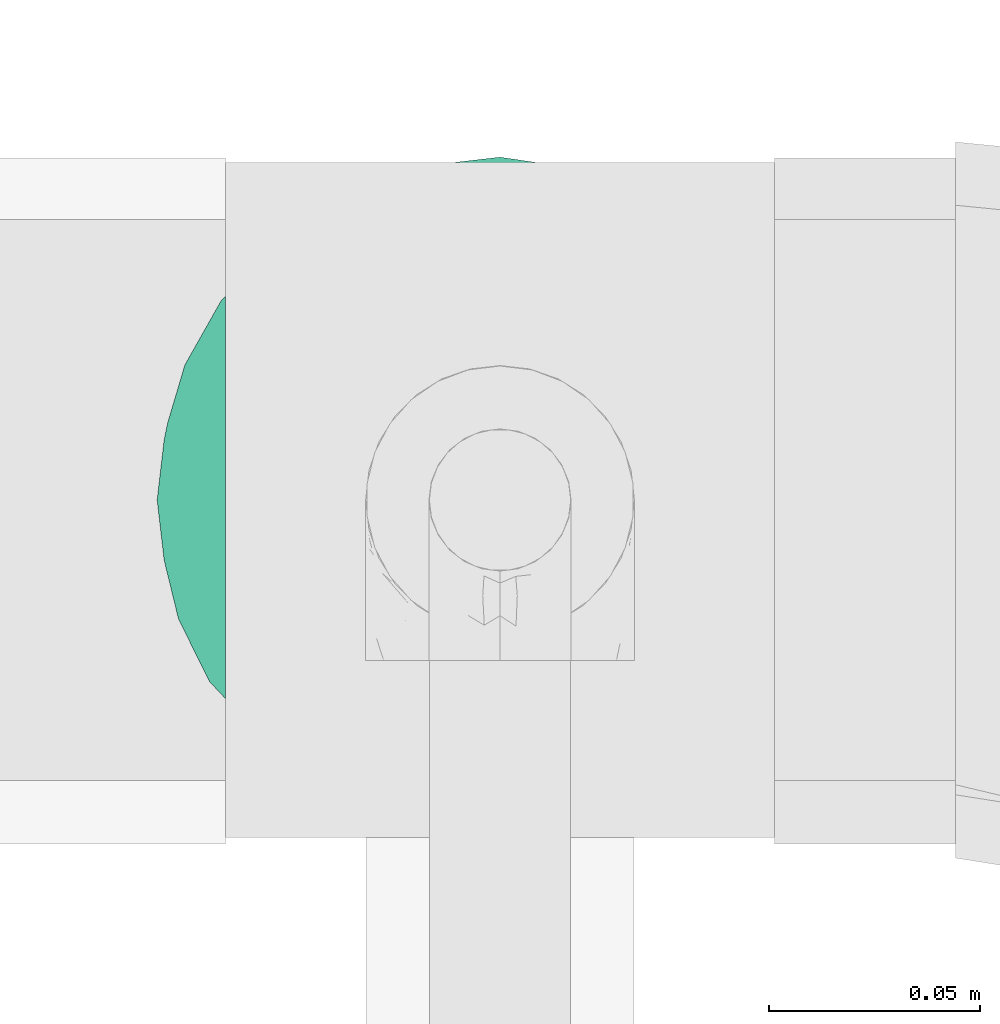
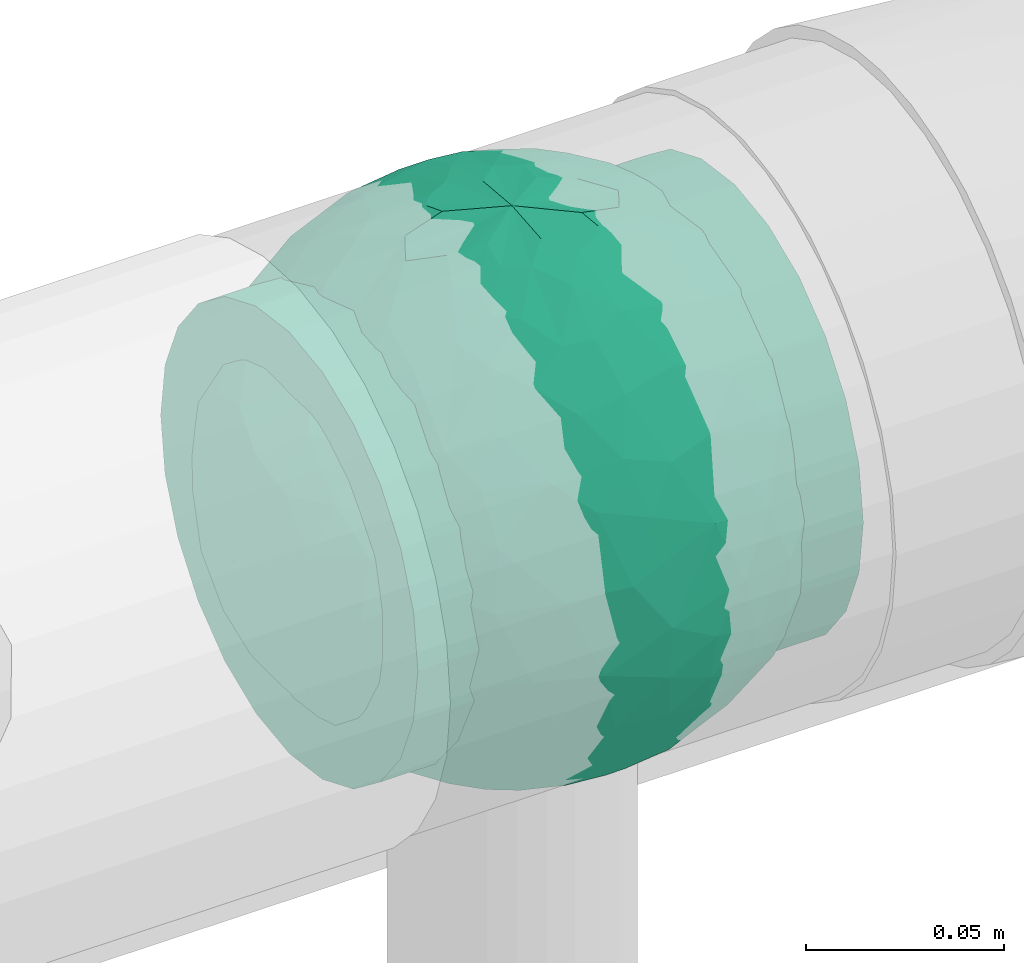
# One storey, part 808 of 827: 1 flow fitting.
"""IFC2X3 building model written with IfcOpenShell, lengths in millimetres."""

from ifc_helpers import new_model, entity, si_unit, converted_unit, derived_unit, direction, frame, origin, place, context, subcontext, project, spatial, faceted_brep, source, transform, mapped, material, material_list, type_object, type_shapes, element, save


model = new_model("IFC2X3")

# Units and contexts
model_context = context("Model", 3, precision=0.01, world=origin(), true_north=direction((6.12303176911189e-17, 1.0)))
body_context = subcontext(model_context, "Body", "Model", "MODEL_VIEW")
ifc_project = project(units=[si_unit("LENGTHUNIT", "METRE", prefix="MILLI"), si_unit("AREAUNIT", "SQUARE_METRE"), si_unit("VOLUMEUNIT", "CUBIC_METRE"), converted_unit("PLANEANGLEUNIT", "DEGREE", entity("IfcRatioMeasure", 0.0174532925199433), si_unit("PLANEANGLEUNIT", "RADIAN"), dimensions=[0, 0, 0, 0, 0, 0, 0]), si_unit("MASSUNIT", "GRAM", prefix="KILO"), derived_unit("MASSDENSITYUNIT", [(si_unit("MASSUNIT", "GRAM", prefix="KILO"), 1), (si_unit("LENGTHUNIT", "METRE"), -3)]), derived_unit("MOMENTOFINERTIAUNIT", [(si_unit("LENGTHUNIT", "METRE"), 4)]), si_unit("TIMEUNIT", "SECOND"), si_unit("FREQUENCYUNIT", "HERTZ"), si_unit("THERMODYNAMICTEMPERATUREUNIT", "DEGREE_CELSIUS"), derived_unit("THERMALTRANSMITTANCEUNIT", [(si_unit("MASSUNIT", "GRAM", prefix="KILO"), 1), (si_unit("THERMODYNAMICTEMPERATUREUNIT", "KELVIN"), -1), (si_unit("TIMEUNIT", "SECOND"), -3)]), derived_unit("VOLUMETRICFLOWRATEUNIT", [(si_unit("LENGTHUNIT", "METRE"), 3), (si_unit("TIMEUNIT", "SECOND"), -1)]), derived_unit("MASSFLOWRATEUNIT", [(si_unit("MASSUNIT", "GRAM", prefix="KILO"), 1), (si_unit("TIMEUNIT", "SECOND"), -1)]), derived_unit("ROTATIONALFREQUENCYUNIT", [(si_unit("TIMEUNIT", "SECOND"), -1)]), si_unit("ELECTRICCURRENTUNIT", "AMPERE"), si_unit("ELECTRICVOLTAGEUNIT", "VOLT"), si_unit("POWERUNIT", "WATT"), si_unit("FORCEUNIT", "NEWTON", prefix="KILO"), si_unit("ILLUMINANCEUNIT", "LUX"), si_unit("LUMINOUSFLUXUNIT", "LUMEN"), si_unit("LUMINOUSINTENSITYUNIT", "CANDELA"), derived_unit("USERDEFINED", [(si_unit("MASSUNIT", "GRAM", prefix="KILO"), -1), (si_unit("LENGTHUNIT", "METRE"), -2), (si_unit("TIMEUNIT", "SECOND"), 3), (si_unit("LUMINOUSFLUXUNIT", "LUMEN"), 1)]), derived_unit("LINEARVELOCITYUNIT", [(si_unit("LENGTHUNIT", "METRE"), 1), (si_unit("TIMEUNIT", "SECOND"), -1)]), si_unit("PRESSUREUNIT", "PASCAL"), derived_unit("USERDEFINED", [(si_unit("LENGTHUNIT", "METRE"), -2), (si_unit("MASSUNIT", "GRAM", prefix="KILO"), 1), (si_unit("TIMEUNIT", "SECOND"), -2)]), derived_unit("LINEARFORCEUNIT", [(si_unit("MASSUNIT", "GRAM", prefix="KILO"), 1), (si_unit("LENGTHUNIT", "METRE"), 1), (si_unit("TIMEUNIT", "SECOND"), -2), (si_unit("LENGTHUNIT", "METRE"), -1)]), derived_unit("PLANARFORCEUNIT", [(si_unit("MASSUNIT", "GRAM", prefix="KILO"), 1), (si_unit("LENGTHUNIT", "METRE"), 1), (si_unit("TIMEUNIT", "SECOND"), -2), (si_unit("LENGTHUNIT", "METRE"), -2)])], contexts=[model_context])

# Site, building, storey
site_placement = place(None, origin())
site = spatial("IfcSite", under=ifc_project, at=site_placement, CompositionType="ELEMENT")
building_placement = place(site_placement, origin())
building = spatial("IfcBuilding", under=site, at=building_placement, CompositionType="ELEMENT")
storey_placement = place(building_placement, frame((0.0, 0.0, 28200.0)))
storey = spatial("IfcBuildingStorey", under=building, at=storey_placement, Name="08", CompositionType="ELEMENT", Elevation=28200.0)

# Flow fitting
ifc_material_1 = material()
ifc_material_2 = material(Name="ADSK_")
ifc_material_list = material_list([ifc_material_1, ifc_material_2])
pipe_fitting_type = type_object("IfcPipeFittingType", Name="ADSK_1", PredefinedType="NOTDEFINED", material=ifc_material_list)
shared_shape = source(origin(), body_context, "Body", "Brep", [
    faceted_brep([(-65.0, 32.5, -56.29), (-65.0, 16.82, -62.79), (-65.0, 0.0, -65.0), (-65.0, -16.82, -62.79), (-65.0, -32.5, -56.29), (-65.0, -45.96, -45.96), (-65.0, -56.29, -32.5), (-65.0, -62.79, -16.82), (-65.0, -65.0, 0.0), (-65.0, -62.79, 16.82), (-65.0, -56.29, 32.5), (-65.0, -45.96, 45.96), (-65.0, -32.5, 56.29), (-65.0, -16.82, 62.79), (-65.0, 0.0, 65.0), (-65.0, 16.82, 62.79), (-65.0, 32.5, 56.29), (-65.0, 45.96, 45.96), (-65.0, 56.29, 32.5), (-65.0, 62.79, 16.82), (-65.0, 65.0, 0.0), (-65.0, 62.79, -16.82), (-65.0, 56.29, -32.5), (-65.0, 45.96, -45.96), (65.0, 0.0, -65.0), (65.0, 16.82, -62.79), (65.0, 32.5, -56.29), (65.0, 45.96, -45.96), (65.0, 56.29, -32.5), (65.0, 62.79, -16.82), (65.0, 65.0, 0.0), (65.0, 62.79, 16.82), (65.0, 56.29, 32.5), (65.0, 45.96, 45.96), (65.0, 32.5, 56.29), (65.0, 16.82, 62.79), (65.0, 0.0, 65.0), (65.0, -16.82, 62.79), (65.0, -32.5, 56.29), (65.0, -45.96, 45.96), (65.0, -56.29, 32.5), (65.0, -62.79, 16.82), (65.0, -65.0, 0.0), (65.0, -62.79, -16.82), (65.0, -56.29, -32.5), (65.0, -45.96, -45.96), (65.0, -32.5, -56.29), (65.0, -16.82, -62.79), (14.09, -64.8, 5.14), (14.55, -64.9, 2.57), (15.0, -65.0, 0.0), (11.49, -64.28, 9.65), (2.61, -63.3, 14.77), (5.06, -63.49, 13.88), (7.51, -63.69, 12.98), (-14.09, -64.8, 5.14), (-11.49, -64.28, 9.64), (-15.0, -65.0, 0.0), (-14.55, -64.9, 2.57), (-7.51, -63.69, 12.98), (-5.06, -63.49, 13.88), (-2.61, -63.3, 14.77), (0.0, -63.3, 14.77), (2.61, -63.3, -14.77), (7.51, -63.69, -12.98), (5.06, -63.49, -13.88), (14.55, -64.9, -2.57), (14.09, -64.8, -5.14), (11.49, -64.28, -9.65), (0.0, -63.3, -14.77), (-2.61, -63.3, -14.77), (-5.06, -63.49, -13.88), (-7.51, -63.69, -12.98), (-11.49, -64.28, -9.64), (-14.09, -64.8, -5.14), (-14.55, -64.9, -2.57), (10.61, -70.0, -10.61), (12.99, -70.0, -7.5), (14.49, -70.0, -3.88), (15.0, -70.0, 0.0), (14.49, -70.0, 3.88), (12.99, -70.0, 7.5), (10.61, -70.0, 10.61), (7.5, -70.0, 12.99), (3.88, -70.0, 14.49), (0.0, -70.0, 15.0), (-3.88, -70.0, 14.49), (-7.5, -70.0, 12.99), (-10.61, -70.0, 10.61), (-12.99, -70.0, 7.5), (-14.49, -70.0, 3.88), (-15.0, -70.0, 0.0), (-14.49, -70.0, -3.88), (-12.99, -70.0, -7.5), (-10.61, -70.0, -10.61), (-7.5, -70.0, -12.99), (-3.88, -70.0, -14.49), (0.0, -70.0, -15.0), (3.88, -70.0, -14.49), (7.5, -70.0, -12.99)], [[[0, 1, 2, 3, 4, 5, 6, 7, 8, 9, 10, 11, 12, 13, 14, 15, 16, 17, 18, 19, 20, 21, 22, 23]], [[24, 25, 26, 27, 28, 29, 30, 31, 32, 33, 34, 35, 36, 37, 38, 39, 40, 41, 42, 43, 44, 45, 46, 47]], [[42, 48, 49, 50]], [[51, 48, 42]], [[42, 41, 51]], [[52, 40, 10]], [[41, 52, 53, 54]], [[41, 54, 51]], [[52, 41, 40]], [[40, 39, 11, 10]], [[55, 56, 8]], [[8, 57, 58, 55]], [[56, 9, 8]], [[9, 59, 60, 61]], [[61, 10, 9]], [[10, 61, 62, 52]], [[59, 9, 56]], [[39, 38, 12, 11]], [[14, 13, 37, 36]], [[13, 12, 38, 37]], [[15, 14, 36, 35]], [[32, 31, 19, 18]], [[17, 16, 34, 33]], [[18, 17, 33, 32]], [[35, 34, 16, 15]], [[20, 19, 31, 30]], [[20, 30, 29, 21]], [[22, 28, 27, 23]], [[21, 29, 28, 22]], [[24, 47, 3, 2]], [[1, 0, 26, 25]], [[2, 1, 25, 24]], [[26, 0, 23, 27]], [[46, 4, 3, 47]], [[46, 45, 5, 4]], [[44, 43, 63]], [[6, 44, 63]], [[44, 6, 5, 45]], [[43, 64, 65, 63]], [[42, 50, 66, 67]], [[64, 43, 68]], [[67, 68, 42]], [[68, 43, 42]], [[6, 63, 69, 70]], [[7, 6, 70]], [[7, 70, 71, 72]], [[73, 8, 7]], [[8, 74, 75, 57]], [[74, 8, 73]], [[73, 7, 72]], [[76, 77, 78, 79, 80, 81, 82, 83, 84, 85, 86, 87, 88, 89, 90, 91, 92, 93, 94, 95, 96, 97, 98, 99]], [[90, 58, 91]], [[56, 89, 88]], [[90, 89, 55]], [[88, 87, 59]], [[90, 55, 58]], [[58, 57, 91]], [[55, 89, 56]], [[60, 59, 87]], [[86, 61, 60]], [[59, 56, 88]], [[85, 52, 62, 61]], [[83, 53, 84]], [[49, 48, 80]], [[52, 85, 84]], [[53, 83, 54]], [[51, 82, 81]], [[83, 82, 54]], [[48, 81, 80]], [[82, 51, 54]], [[52, 84, 53]], [[49, 79, 50]], [[79, 49, 80]], [[48, 51, 81]], [[60, 87, 86]], [[85, 61, 86]], [[78, 66, 79]], [[68, 77, 76]], [[78, 77, 67]], [[76, 99, 64]], [[78, 67, 66]], [[66, 50, 79]], [[67, 77, 68]], [[65, 64, 99]], [[98, 63, 65]], [[64, 68, 76]], [[97, 70, 69, 63]], [[95, 71, 96]], [[75, 74, 92]], [[70, 97, 96]], [[71, 95, 72]], [[73, 94, 93]], [[72, 95, 94]], [[74, 93, 92]], [[94, 73, 72]], [[70, 96, 71]], [[75, 91, 57]], [[91, 75, 92]], [[74, 73, 93]], [[65, 99, 98]], [[97, 63, 98]]]),
    faceted_brep([(-26.57, 76.36, -8.07), (-32.83, 71.49, -20.33), (-47.03, 64.85, -13.55), (22.24, -77.88, -6.48), (0.0, -81.25, 0.0), (14.57, -79.42, -9.02), (-19.55, 43.65, -65.68), (-6.7, 41.88, -69.3), (-15.5, 23.94, -76.08), (15.55, -78.16, 0.0), (20.63, -67.73, -39.86), (17.31, -55.39, -56.87), (33.39, -55.07, -49.54), (6.89, -77.99, -21.73), (13.76, -77.98, -18.22), (0.0, -79.9, -14.73), (-69.67, 30.72, -28.35), (-63.35, 45.14, -23.48), (-60.56, 38.81, -37.79), (-44.27, 66.26, 0.0), (8.9, -68.68, -42.49), (0.0, -57.53, -57.37), (-48.93, 45.14, -46.58), (-49.03, 57.11, -30.6), (-35.46, 62.54, -37.85), (76.18, -1.07, -28.23), (78.6, -12.72, -16.17), (71.53, -15.85, -35.12), (10.46, 67.82, -43.51), (0.0, 75.3, -30.53), (6.86, 78.01, -21.66), (-10.53, -67.73, -43.64), (0.0, -75.25, -30.63), (-6.89, -77.99, -21.73), (0.0, 81.25, 0.0), (15.55, 78.16, 0.0), (22.61, 77.77, -6.46), (-12.72, -56.34, -57.14), (-5.46, -45.53, -67.07), (44.37, 62.32, -27.38), (43.44, 67.56, -12.26), (56.18, 55.82, -18.18), (-13.79, 77.96, -18.26), (-25.89, 72.59, -25.72), (-16.58, 78.16, -14.76), (75.07, 31.09, 0.0), (74.86, 27.47, -15.59), (67.53, 42.93, -14.07), (13.79, 77.96, -18.26), (12.84, 79.64, -9.7), (21.38, 75.85, -19.79), (74.72, 15.85, -27.69), (79.59, 7.96, -14.27), (43.73, -67.56, -11.18), (57.45, -57.45, 0.0), (44.27, -66.26, 0.0), (63.35, -45.14, -23.48), (61.82, -51.54, -11.09), (49.12, -59.87, -24.59), (78.16, 15.55, 0.0), (50.83, -12.03, -62.24), (35.62, -9.55, -72.4), (43.7, 11.32, -67.56), (72.48, -29.04, -22.46), (-44.38, -62.32, -27.37), (-26.83, -74.87, -16.61), (-43.44, -67.56, -12.26), (-13.76, -77.98, -18.22), (-12.85, -79.64, -9.7), (-21.39, -75.84, -19.81), (-2.49, -31.04, -75.05), (8.59, -44.22, -67.62), (-74.72, -15.85, -27.69), (-68.67, -30.94, -30.47), (-74.55, -27.6, -16.8), (-75.07, 31.09, 0.0), (-71.41, 36.12, -14.04), (-75.88, 22.59, -18.27), (-22.61, -77.77, -6.46), (-16.87, -79.04, -8.34), (28.21, -26.53, -71.43), (13.03, -29.67, -74.51), (18.2, -9.78, -78.58), (-56.42, -55.66, -17.92), (6.0, 45.8, -66.84), (0.0, 57.69, -57.22), (-78.16, -15.55, 0.0), (-79.59, -7.96, -14.27), (32.83, -71.49, -20.33), (-15.55, -78.16, 0.0), (-20.62, 67.82, -39.72), (-33.11, 50.34, -54.51), (-61.82, 51.54, -11.09), (-66.26, 44.27, 0.0), (75.07, -31.09, 0.0), (66.26, -44.27, 0.0), (-6.86, 78.01, -21.66), (0.0, 79.92, -14.67), (26.82, 74.88, -16.61), (16.85, 79.04, -8.33), (-8.98, 69.99, -40.29), (38.78, -61.98, -35.46), (48.93, -45.14, -46.58), (55.26, -48.62, -34.41), (-71.53, 15.85, -35.12), (-78.76, 7.96, -18.29), (-17.06, 58.9, -53.31), (-15.55, 78.16, 0.0), (13.32, 55.85, -57.49), (21.86, 61.99, -47.75), (-15.13, 79.31, -9.05), (26.19, -72.28, -26.28), (17.27, -77.87, -15.49), (-29.57, -28.73, -70.02), (-26.25, -43.22, -63.6), (-42.18, -36.82, -58.88), (41.25, 41.74, -56.2), (54.79, 33.3, -49.91), (40.91, 28.53, -64.14), (38.98, -38.31, -60.12), (52.67, -28.88, -54.71), (68.84, 3.22, -43.04), (66.02, 21.29, -42.31), (-42.82, 33.53, -60.37), (-55.21, 10.46, -58.69), (-57.08, 27.98, -50.61), (-56.33, -15.85, -56.37), (-55.8, -33.3, -48.77), (-66.18, -20.5, -42.45), (31.09, 75.07, 0.0), (44.27, 66.26, 0.0), (57.45, 57.45, 0.0), (-31.09, -75.07, 0.0), (-57.45, -57.45, 0.0), (1.56, 67.82, -44.72), (-1.57, -67.73, -44.86), (22.55, 72.77, -28.25), (16.53, 72.17, -33.48), (-22.52, -72.77, -28.27), (-16.58, -72.47, -32.79), (28.96, -66.23, -37.11), (62.57, -34.08, -39.05), (62.37, -15.41, -49.74), (68.82, 31.09, -29.97), (-66.06, -1.38, -47.28), (-67.87, -42.27, -14.43), (29.1, 65.34, -38.54), (33.22, 68.08, -29.37), (46.02, 49.13, -45.5), (10.35, 15.34, -79.12), (0.0, 0.22, -81.25), (-29.12, -65.31, -38.57), (-22.07, -61.55, -48.23), (-33.19, -68.12, -29.33), (-46.02, -49.17, -45.45), (-34.11, 19.17, -71.21), (-23.02, 4.97, -77.76), (-40.38, 0.85, -70.5), (2.47, 31.35, -74.92), (16.3, 35.47, -71.26), (-13.73, -8.11, -79.67), (-28.12, -13.42, -75.04), (33.83, 54.01, -50.4), (26.1, 43.46, -63.49), (24.94, -42.3, -64.73), (-16.13, -35.64, -71.21), (0.28, -15.85, -79.69), (-13.57, -22.47, -76.89), (60.35, 45.14, -30.37), (-60.34, -45.14, -30.38), (-33.99, -54.1, -50.2), (-57.45, 57.45, 0.0), (-42.67, -18.04, -66.75), (-63.99, 15.14, -47.72), (-81.25, 0.0, 0.0), (-78.16, 15.55, 0.0), (-74.66, 0.0, -32.06), (-31.09, 75.07, 0.0), (31.09, -75.07, 0.0), (56.37, 15.85, -56.33), (28.0, 13.82, -75.01), (66.26, 44.27, 0.0), (81.25, 0.0, 0.0), (78.16, -15.55, 0.0), (-66.26, -44.27, 0.0), (-75.07, -31.09, 0.0), (-44.27, -66.26, 0.0), (26.57, 76.36, 8.07), (32.83, 71.49, 20.33), (47.03, 64.85, 13.55), (-22.24, -77.88, 6.48), (-14.57, -79.42, 9.02), (19.55, 43.65, 65.68), (6.7, 41.88, 69.3), (15.5, 23.94, 76.08), (-20.63, -67.73, 39.86), (-17.31, -55.39, 56.87), (-33.39, -55.07, 49.54), (-6.89, -77.99, 21.73), (-13.76, -77.98, 18.22), (0.0, -79.9, 14.73), (69.67, 30.72, 28.35), (63.35, 45.14, 23.48), (60.56, 38.81, 37.79), (-8.9, -68.68, 42.49), (0.0, -57.53, 57.37), (48.93, 45.14, 46.58), (49.03, 57.11, 30.6), (35.46, 62.54, 37.85), (-76.18, -1.07, 28.23), (-78.6, -12.72, 16.17), (-71.53, -15.85, 35.12), (-10.46, 67.82, 43.51), (0.0, 75.3, 30.53), (-6.86, 78.01, 21.66), (10.53, -67.73, 43.64), (0.0, -75.25, 30.63), (6.89, -77.99, 21.73), (-22.61, 77.77, 6.46), (12.72, -56.34, 57.14), (5.46, -45.53, 67.07), (-44.37, 62.32, 27.38), (-43.44, 67.56, 12.26), (-56.18, 55.82, 18.18), (13.79, 77.96, 18.26), (25.89, 72.59, 25.72), (16.58, 78.16, 14.76), (-74.86, 27.47, 15.59), (-67.53, 42.93, 14.07), (-13.79, 77.96, 18.26), (-12.84, 79.64, 9.7), (-21.38, 75.85, 19.79), (-74.72, 15.85, 27.69), (-79.59, 7.96, 14.27), (-43.73, -67.56, 11.18), (-63.35, -45.14, 23.48), (-61.82, -51.54, 11.09), (-49.12, -59.87, 24.59), (-50.83, -12.03, 62.24), (-35.62, -9.55, 72.4), (-43.7, 11.32, 67.56), (-72.48, -29.04, 22.46), (44.38, -62.32, 27.37), (26.83, -74.87, 16.61), (43.44, -67.56, 12.26), (13.76, -77.98, 18.22), (12.85, -79.64, 9.7), (21.39, -75.84, 19.81), (2.49, -31.04, 75.05), (-8.59, -44.22, 67.62), (74.72, -15.85, 27.69), (68.67, -30.94, 30.47), (74.55, -27.6, 16.8), (71.41, 36.12, 14.04), (75.88, 22.59, 18.27), (22.61, -77.77, 6.46), (16.87, -79.04, 8.34), (-28.21, -26.53, 71.43), (-13.03, -29.67, 74.51), (-18.2, -9.78, 78.58), (56.42, -55.66, 17.92), (-6.0, 45.8, 66.84), (0.0, 57.69, 57.22), (78.78, -14.01, 14.13), (-32.83, -71.49, 20.33), (20.62, 67.82, 39.72), (33.11, 50.34, 54.51), (61.82, 51.54, 11.09), (6.86, 78.01, 21.66), (0.0, 79.92, 14.67), (-26.82, 74.88, 16.61), (-16.85, 79.04, 8.33), (8.98, 69.99, 40.29), (-38.78, -61.98, 35.46), (-48.93, -45.14, 46.58), (-55.26, -48.62, 34.41), (71.53, 15.85, 35.12), (78.76, 7.96, 18.29), (17.06, 58.9, 53.31), (-13.32, 55.85, 57.49), (-21.86, 61.99, 47.75), (15.13, 79.31, 9.05), (-26.19, -72.28, 26.28), (-17.27, -77.87, 15.49), (29.57, -28.73, 70.02), (26.25, -43.22, 63.6), (42.18, -36.82, 58.88), (-41.25, 41.74, 56.2), (-54.79, 33.3, 49.91), (-40.91, 28.53, 64.14), (-38.98, -38.31, 60.12), (-52.67, -28.88, 54.71), (-68.84, 3.22, 43.04), (-66.02, 21.29, 42.31), (42.82, 33.53, 60.37), (55.21, 10.46, 58.69), (57.08, 27.98, 50.61), (56.33, -15.85, 56.37), (55.8, -33.3, 48.77), (66.18, -20.5, 42.45), (-1.56, 67.82, 44.72), (1.57, -67.73, 44.86), (-22.55, 72.77, 28.25), (-16.53, 72.17, 33.48), (22.52, -72.77, 28.27), (16.58, -72.47, 32.79), (-28.96, -66.23, 37.11), (-62.57, -34.08, 39.05), (-62.37, -15.41, 49.74), (-68.82, 31.09, 29.97), (66.06, -1.38, 47.28), (67.87, -42.27, 14.43), (-29.1, 65.34, 38.54), (-33.22, 68.08, 29.37), (-46.02, 49.13, 45.5), (-10.35, 15.34, 79.12), (0.0, 0.22, 81.25), (29.12, -65.31, 38.57), (22.07, -61.55, 48.23), (33.19, -68.12, 29.33), (46.02, -49.17, 45.45), (34.11, 19.17, 71.21), (23.02, 4.97, 77.76), (40.38, 0.85, 70.5), (-2.47, 31.35, 74.92), (-16.3, 35.47, 71.26), (13.73, -8.11, 79.67), (28.12, -13.42, 75.04), (-33.83, 54.01, 50.4), (-26.1, 43.46, 63.49), (-24.94, -42.3, 64.73), (16.13, -35.64, 71.21), (-0.28, -15.85, 79.69), (13.57, -22.47, 76.89), (-60.35, 45.14, 30.37), (60.34, -45.14, 30.38), (33.99, -54.1, 50.2), (42.67, -18.04, 66.75), (63.99, 15.14, 47.72), (74.66, 0.0, 32.06), (-56.37, 15.85, 56.33), (-28.0, 13.82, 75.01)], [[[0, 1, 2]], [[3, 4, 5]], [[6, 7, 8]], [[4, 3, 9]], [[10, 11, 12]], [[13, 14, 4]], [[13, 4, 15]], [[16, 17, 18]], [[19, 0, 2]], [[20, 21, 11]], [[22, 23, 24]], [[25, 26, 27]], [[28, 29, 30]], [[31, 32, 33]], [[34, 35, 36]], [[37, 38, 21]], [[39, 40, 41]], [[42, 43, 44]], [[45, 46, 47]], [[30, 34, 48]], [[49, 50, 48]], [[51, 46, 52]], [[53, 54, 55]], [[56, 57, 58]], [[46, 59, 52]], [[60, 61, 62]], [[27, 26, 63]], [[64, 65, 66]], [[67, 68, 69]], [[38, 70, 71]], [[72, 73, 74]], [[15, 33, 32]], [[75, 76, 77]], [[78, 65, 79]], [[80, 81, 82]], [[64, 66, 83]], [[84, 7, 85]], [[74, 86, 87]], [[88, 53, 3]], [[4, 89, 78]], [[24, 90, 91]], [[92, 76, 93]], [[94, 95, 63]], [[96, 34, 97]], [[36, 98, 99]], [[96, 42, 34]], [[96, 100, 90]], [[101, 102, 103]], [[77, 104, 105]], [[90, 106, 91]], [[34, 0, 107]], [[84, 85, 108]], [[109, 108, 28]], [[0, 110, 1]], [[14, 111, 112]], [[97, 30, 29]], [[39, 98, 40]], [[67, 33, 4]], [[113, 114, 115]], [[116, 117, 118]], [[119, 60, 120]], [[121, 122, 51]], [[123, 124, 125]], [[126, 127, 128]], [[129, 40, 36]], [[130, 131, 40]], [[132, 66, 78]], [[133, 83, 66]], [[97, 29, 96]], [[28, 108, 134]], [[100, 96, 29]], [[44, 34, 42]], [[15, 32, 13]], [[32, 31, 135]], [[20, 13, 32]], [[112, 4, 14]], [[48, 136, 137]], [[96, 90, 42]], [[90, 24, 43]], [[68, 67, 4]], [[67, 138, 139]], [[13, 10, 14]], [[140, 101, 111]], [[53, 58, 57]], [[141, 102, 120]], [[27, 142, 121]], [[46, 51, 143]], [[23, 2, 1]], [[125, 18, 22]], [[124, 126, 144]], [[73, 145, 74]], [[30, 137, 28]], [[28, 137, 109]], [[146, 147, 148]], [[149, 150, 8]], [[151, 152, 139]], [[152, 114, 37]], [[151, 153, 154]], [[155, 156, 157]], [[158, 84, 159]], [[156, 8, 150]], [[156, 160, 161]], [[155, 124, 123]], [[162, 116, 163]], [[119, 80, 60]], [[12, 102, 101]], [[81, 164, 71]], [[91, 123, 22]], [[100, 106, 90]], [[70, 38, 165]], [[81, 70, 166]], [[167, 113, 161]], [[156, 161, 157]], [[131, 47, 41]], [[36, 40, 98]], [[148, 39, 168]], [[146, 136, 147]], [[143, 117, 168]], [[146, 162, 109]], [[99, 34, 36]], [[133, 145, 83]], [[78, 66, 65]], [[154, 64, 169]], [[151, 138, 153]], [[115, 127, 126]], [[151, 170, 152]], [[79, 4, 78]], [[134, 100, 29]], [[85, 7, 106]], [[85, 106, 100]], [[91, 106, 6]], [[123, 6, 155]], [[91, 22, 24]], [[22, 18, 23]], [[43, 24, 1]], [[92, 17, 76]], [[1, 24, 23]], [[17, 2, 23]], [[92, 171, 2]], [[110, 0, 34]], [[6, 123, 91]], [[157, 161, 172]], [[144, 126, 128]], [[123, 125, 22]], [[124, 173, 125]], [[104, 16, 18]], [[18, 125, 173]], [[23, 18, 17]], [[105, 174, 175]], [[76, 17, 16]], [[105, 176, 87]], [[77, 175, 75]], [[176, 105, 104]], [[77, 76, 16]], [[76, 75, 93]], [[93, 171, 92]], [[177, 0, 19]], [[2, 17, 92]], [[104, 77, 16]], [[175, 77, 105]], [[3, 53, 178]], [[53, 88, 58]], [[88, 3, 5]], [[101, 58, 88]], [[56, 103, 141]], [[111, 101, 88]], [[101, 140, 12]], [[10, 20, 11]], [[119, 102, 12]], [[71, 70, 81]], [[119, 164, 80]], [[164, 12, 11]], [[80, 82, 61]], [[51, 25, 121]], [[119, 120, 102]], [[13, 20, 10]], [[20, 32, 135]], [[60, 142, 120]], [[56, 58, 103]], [[142, 141, 120]], [[63, 141, 27]], [[121, 60, 179]], [[141, 142, 27]], [[60, 121, 142]], [[122, 121, 179]], [[117, 122, 179]], [[143, 51, 122]], [[117, 179, 118]], [[168, 117, 148]], [[62, 118, 179]], [[159, 118, 180]], [[117, 143, 122]], [[143, 168, 47]], [[41, 47, 168]], [[47, 131, 181]], [[47, 46, 143]], [[46, 45, 59]], [[59, 182, 52]], [[26, 52, 182]], [[25, 51, 52]], [[26, 182, 183]], [[95, 57, 63]], [[26, 25, 52]], [[121, 25, 27]], [[94, 63, 26]], [[141, 63, 56]], [[53, 57, 54]], [[54, 57, 95]], [[63, 57, 56]], [[39, 41, 168]], [[41, 40, 131]], [[12, 164, 119]], [[164, 11, 71]], [[11, 21, 71]], [[38, 71, 21]], [[21, 135, 37]], [[38, 37, 165]], [[152, 37, 31]], [[165, 37, 114]], [[139, 31, 33]], [[151, 154, 170]], [[31, 139, 152]], [[67, 139, 33]], [[113, 165, 114]], [[167, 161, 160]], [[114, 170, 115]], [[172, 161, 113]], [[127, 115, 154]], [[172, 115, 126]], [[115, 172, 113]], [[157, 126, 124]], [[126, 157, 172]], [[124, 155, 157]], [[8, 156, 155]], [[160, 156, 150]], [[6, 8, 155]], [[8, 158, 149]], [[154, 169, 127]], [[128, 73, 72]], [[73, 127, 169]], [[176, 144, 128]], [[176, 128, 72]], [[173, 144, 104]], [[115, 170, 154]], [[114, 152, 170]], [[127, 73, 128]], [[73, 169, 145]], [[83, 145, 169]], [[145, 133, 184]], [[145, 185, 74]], [[74, 185, 86]], [[87, 86, 174]], [[105, 87, 174]], [[74, 87, 72]], [[64, 83, 169]], [[66, 132, 186]], [[167, 166, 70]], [[164, 81, 80]], [[149, 82, 150]], [[80, 61, 60]], [[82, 180, 61]], [[62, 180, 118]], [[112, 88, 5]], [[140, 14, 10]], [[166, 160, 150]], [[165, 167, 70]], [[150, 82, 166]], [[81, 166, 82]], [[167, 165, 113]], [[166, 167, 160]], [[88, 112, 111]], [[4, 112, 5]], [[144, 176, 104]], [[87, 176, 72]], [[101, 103, 58]], [[102, 141, 103]], [[60, 62, 179]], [[61, 180, 62]], [[14, 140, 111]], [[12, 140, 10]], [[48, 137, 30]], [[109, 137, 146]], [[162, 146, 148]], [[108, 85, 134]], [[109, 163, 108]], [[163, 159, 84]], [[116, 162, 148]], [[163, 109, 162]], [[163, 84, 108]], [[7, 84, 158]], [[118, 159, 163]], [[149, 159, 180]], [[8, 7, 158]], [[7, 6, 106]], [[117, 116, 148]], [[163, 116, 118]], [[98, 49, 99]], [[50, 49, 98]], [[34, 49, 48]], [[147, 98, 39]], [[136, 48, 50]], [[147, 39, 148]], [[137, 136, 146]], [[136, 50, 147]], [[98, 147, 50]], [[34, 99, 49]], [[65, 68, 79]], [[68, 65, 69]], [[153, 65, 64]], [[138, 67, 69]], [[153, 64, 154]], [[139, 138, 151]], [[138, 69, 153]], [[65, 153, 69]], [[4, 79, 68]], [[34, 30, 97]], [[4, 33, 15]], [[100, 134, 85]], [[29, 28, 134]], [[37, 135, 31]], [[20, 135, 21]], [[159, 149, 158]], [[82, 149, 180]], [[40, 129, 130]], [[186, 133, 66]], [[44, 1, 110]], [[90, 43, 42]], [[1, 44, 43]], [[34, 44, 110]], [[2, 171, 19]], [[0, 177, 107]], [[144, 173, 124]], [[18, 173, 104]], [[3, 178, 9]], [[55, 178, 53]], [[181, 45, 47]], [[94, 26, 183]], [[184, 185, 145]], [[35, 129, 36]], [[89, 132, 78]], [[187, 188, 189]], [[190, 4, 191]], [[192, 193, 194]], [[4, 190, 89]], [[195, 196, 197]], [[198, 199, 4]], [[198, 4, 200]], [[201, 202, 203]], [[130, 187, 189]], [[204, 205, 196]], [[206, 207, 208]], [[209, 210, 211]], [[212, 213, 214]], [[215, 216, 217]], [[34, 107, 218]], [[219, 220, 205]], [[221, 222, 223]], [[224, 225, 226]], [[75, 227, 228]], [[214, 34, 229]], [[230, 231, 229]], [[232, 227, 233]], [[234, 133, 186]], [[235, 236, 237]], [[227, 175, 233]], [[238, 239, 240]], [[211, 210, 241]], [[242, 243, 244]], [[245, 246, 247]], [[220, 248, 249]], [[250, 251, 252]], [[200, 217, 216]], [[45, 253, 254]], [[255, 243, 256]], [[257, 258, 259]], [[242, 244, 260]], [[261, 193, 262]], [[252, 183, 263]], [[264, 234, 190]], [[4, 9, 255]], [[208, 265, 266]], [[267, 253, 181]], [[185, 184, 241]], [[268, 34, 269]], [[218, 270, 271]], [[268, 224, 34]], [[268, 272, 265]], [[273, 274, 275]], [[254, 276, 277]], [[265, 278, 266]], [[34, 187, 35]], [[261, 262, 279]], [[280, 279, 212]], [[187, 281, 188]], [[199, 282, 283]], [[269, 214, 213]], [[221, 270, 222]], [[245, 217, 4]], [[284, 285, 286]], [[287, 288, 289]], [[290, 238, 291]], [[292, 293, 232]], [[294, 295, 296]], [[297, 298, 299]], [[177, 222, 218]], [[171, 223, 222]], [[178, 244, 255]], [[54, 260, 244]], [[269, 213, 268]], [[34, 230, 229]], [[212, 279, 300]], [[272, 268, 213]], [[226, 34, 224]], [[200, 216, 198]], [[216, 215, 301]], [[204, 198, 216]], [[229, 302, 303]], [[268, 265, 224]], [[265, 208, 225]], [[246, 245, 4]], [[245, 304, 305]], [[198, 195, 199]], [[306, 273, 282]], [[234, 237, 236]], [[307, 274, 291]], [[211, 308, 292]], [[227, 232, 309]], [[207, 189, 188]], [[296, 203, 206]], [[295, 297, 310]], [[251, 311, 252]], [[214, 303, 212]], [[212, 303, 280]], [[312, 313, 314]], [[315, 316, 194]], [[317, 318, 305]], [[318, 285, 219]], [[317, 319, 320]], [[321, 322, 323]], [[324, 261, 325]], [[322, 194, 316]], [[322, 326, 327]], [[321, 295, 294]], [[328, 287, 329]], [[290, 257, 238]], [[197, 274, 273]], [[258, 330, 249]], [[266, 294, 206]], [[272, 278, 265]], [[248, 220, 331]], [[258, 248, 332]], [[333, 284, 327]], [[322, 327, 323]], [[171, 228, 223]], [[218, 222, 270]], [[314, 221, 334]], [[312, 302, 313]], [[309, 288, 334]], [[312, 328, 280]], [[271, 34, 218]], [[54, 311, 260]], [[255, 244, 243]], [[320, 242, 335]], [[317, 304, 319]], [[286, 298, 297]], [[317, 336, 318]], [[256, 4, 255]], [[300, 272, 213]], [[262, 193, 278]], [[262, 278, 272]], [[266, 278, 192]], [[294, 192, 321]], [[266, 206, 208]], [[206, 203, 207]], [[225, 208, 188]], [[267, 202, 253]], [[188, 208, 207]], [[202, 189, 207]], [[267, 131, 189]], [[281, 187, 34]], [[192, 294, 266]], [[323, 327, 337]], [[310, 297, 299]], [[294, 296, 206]], [[295, 338, 296]], [[276, 201, 203]], [[203, 296, 338]], [[207, 203, 202]], [[277, 182, 59]], [[253, 202, 201]], [[263, 250, 252]], [[254, 59, 45]], [[339, 277, 276]], [[254, 253, 201]], [[253, 45, 181]], [[181, 131, 267]], [[129, 187, 130]], [[189, 202, 267]], [[276, 254, 201]], [[59, 254, 277]], [[190, 234, 132]], [[234, 264, 237]], [[272, 300, 262]], [[264, 190, 191]], [[273, 237, 264]], [[235, 275, 307]], [[282, 273, 264]], [[273, 306, 197]], [[195, 204, 196]], [[290, 274, 197]], [[249, 248, 258]], [[290, 330, 257]], [[330, 197, 196]], [[257, 259, 239]], [[232, 209, 292]], [[290, 291, 274]], [[198, 204, 195]], [[204, 216, 301]], [[238, 308, 291]], [[235, 237, 275]], [[308, 307, 291]], [[241, 307, 211]], [[292, 238, 340]], [[307, 308, 211]], [[238, 292, 308]], [[293, 292, 340]], [[288, 293, 340]], [[309, 232, 293]], [[288, 340, 289]], [[334, 288, 314]], [[240, 289, 340]], [[325, 289, 341]], [[288, 309, 293]], [[309, 334, 228]], [[223, 228, 334]], [[228, 171, 93]], [[228, 227, 309]], [[227, 75, 175]], [[175, 174, 233]], [[210, 233, 174]], [[209, 232, 233]], [[210, 174, 86]], [[184, 236, 241]], [[210, 209, 233]], [[292, 209, 211]], [[185, 241, 210]], [[307, 241, 235]], [[234, 236, 133]], [[133, 236, 184]], [[241, 236, 235]], [[221, 223, 334]], [[222, 177, 19]], [[197, 330, 290]], [[330, 196, 249]], [[196, 205, 249]], [[220, 249, 205]], [[205, 301, 219]], [[220, 219, 331]], [[318, 219, 215]], [[331, 219, 285]], [[305, 215, 217]], [[317, 320, 336]], [[215, 305, 318]], [[245, 305, 217]], [[284, 331, 285]], [[333, 327, 326]], [[285, 336, 286]], [[337, 327, 284]], [[298, 286, 320]], [[337, 286, 297]], [[286, 337, 284]], [[323, 297, 295]], [[297, 323, 337]], [[295, 321, 323]], [[194, 322, 321]], [[326, 322, 316]], [[192, 194, 321]], [[194, 324, 315]], [[320, 335, 298]], [[299, 251, 250]], [[251, 298, 335]], [[339, 310, 299]], [[339, 299, 250]], [[338, 310, 276]], [[286, 336, 320]], [[285, 318, 336]], [[298, 251, 299]], [[251, 335, 311]], [[260, 311, 335]], [[311, 54, 95]], [[311, 94, 252]], [[252, 94, 183]], [[182, 277, 263]], [[182, 263, 183]], [[339, 263, 277]], [[242, 260, 335]], [[244, 178, 55]], [[333, 332, 248]], [[330, 258, 257]], [[315, 259, 316]], [[257, 239, 238]], [[259, 341, 239]], [[240, 341, 289]], [[283, 264, 191]], [[306, 199, 195]], [[332, 326, 316]], [[331, 333, 248]], [[316, 259, 332]], [[258, 332, 259]], [[333, 331, 284]], [[332, 333, 326]], [[264, 283, 282]], [[4, 283, 191]], [[310, 339, 276]], [[263, 339, 250]], [[273, 275, 237]], [[274, 307, 275]], [[238, 240, 340]], [[239, 341, 240]], [[199, 306, 282]], [[197, 306, 195]], [[229, 303, 214]], [[280, 303, 312]], [[328, 312, 314]], [[279, 262, 300]], [[280, 329, 279]], [[329, 325, 261]], [[287, 328, 314]], [[329, 280, 328]], [[329, 261, 279]], [[193, 261, 324]], [[289, 325, 329]], [[315, 325, 341]], [[194, 193, 324]], [[193, 192, 278]], [[288, 287, 314]], [[329, 287, 289]], [[270, 230, 271]], [[231, 230, 270]], [[313, 270, 221]], [[302, 229, 231]], [[313, 221, 314]], [[303, 302, 312]], [[302, 231, 313]], [[270, 313, 231]], [[34, 271, 230]], [[243, 246, 256]], [[246, 243, 247]], [[319, 243, 242]], [[304, 245, 247]], [[319, 242, 320]], [[305, 304, 317]], [[304, 247, 319]], [[243, 319, 247]], [[4, 256, 246]], [[34, 214, 269]], [[4, 217, 200]], [[4, 199, 283]], [[213, 212, 300]], [[219, 301, 215]], [[204, 301, 205]], [[325, 315, 324]], [[259, 315, 341]], [[19, 171, 222]], [[55, 54, 244]], [[226, 188, 281]], [[265, 225, 224]], [[188, 226, 225]], [[34, 226, 281]], [[189, 131, 130]], [[187, 129, 35]], [[310, 338, 295]], [[203, 338, 276]], [[190, 132, 89]], [[186, 132, 234]], [[93, 75, 228]], [[185, 210, 86]], [[95, 94, 311]], [[107, 177, 218]], [[9, 178, 255]]]),
])
type_shapes(pipe_fitting_type, [shared_shape])
flow_fitting_placement = place(storey_placement, frame((60153.13, 18180.1, 2900.0), z_axis=(0.0, -1.0, 0.0), x_axis=(1.0, 0.0, 0.0)))
element("IfcFlowFitting", 1, at=flow_fitting_placement, inside=storey, type_object=pipe_fitting_type, material=ifc_material_list, Name="ADSK_1", ObjectType="ADSK_1", context=body_context, shape_type="MappedRepresentation", body=[
    mapped(shared_shape, transform((0.0, 0.0, 0.0), scale=1.0)),
])

save(model, "model.ifc")
